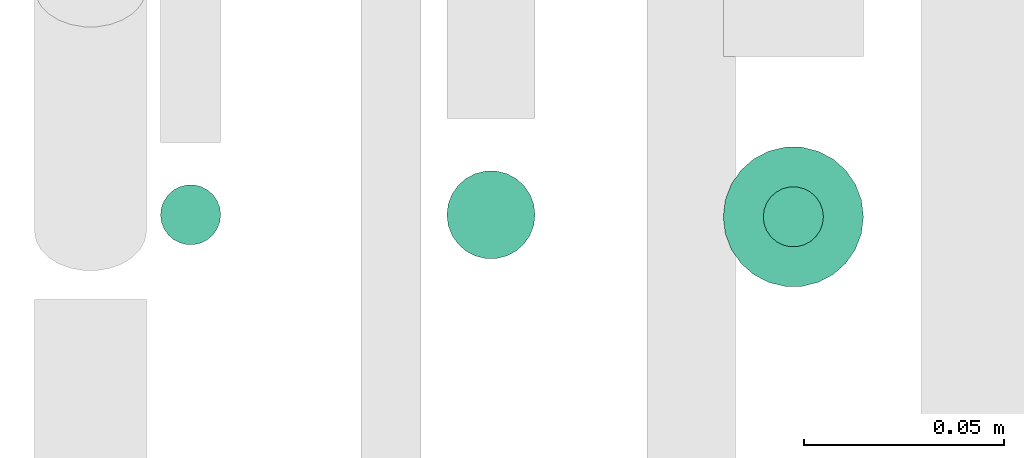
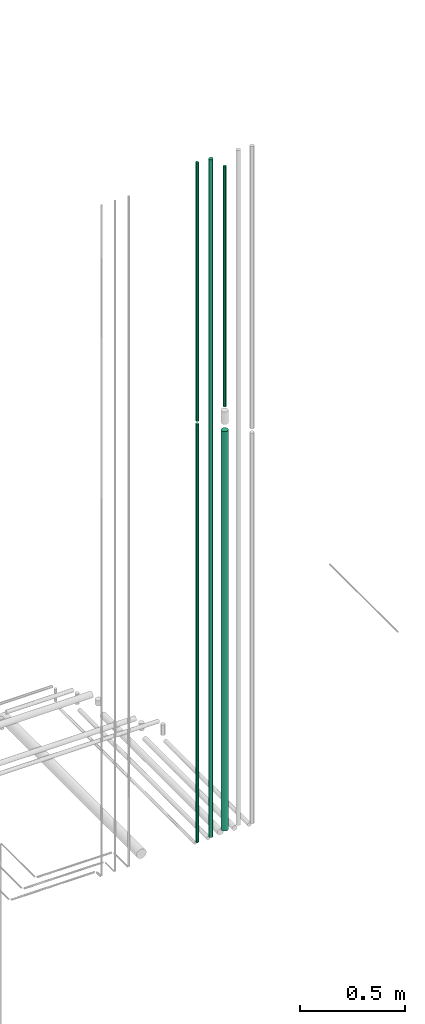
# One storey, part 91 of 331: 5 flow segments.
"""IFC2X3 building model written with IfcOpenShell, lengths in millimetres."""

from ifc_helpers import new_model, entity, si_unit, converted_unit, derived_unit, direction, frame, frame_2d, origin, origin_2d_with_axis, place, context, subcontext, project, spatial, circle, extrude, type_object, element, save


model = new_model("IFC2X3")

# Units and contexts
model_context = context("Model", 3, precision=0.01, world=origin(), true_north=direction((6.12303176911189e-17, 1.0)))
body_context = subcontext(model_context, "Body", "Model", "MODEL_VIEW")
ifc_project = project(units=[si_unit("LENGTHUNIT", "METRE", prefix="MILLI"), si_unit("AREAUNIT", "SQUARE_METRE"), si_unit("VOLUMEUNIT", "CUBIC_METRE"), converted_unit("PLANEANGLEUNIT", "DEGREE", entity("IfcRatioMeasure", 0.0174532925199433), si_unit("PLANEANGLEUNIT", "RADIAN"), dimensions=[0, 0, 0, 0, 0, 0, 0]), si_unit("MASSUNIT", "GRAM", prefix="KILO"), derived_unit("MASSDENSITYUNIT", [(si_unit("MASSUNIT", "GRAM", prefix="KILO"), 1), (si_unit("LENGTHUNIT", "METRE"), -3)]), derived_unit("MOMENTOFINERTIAUNIT", [(si_unit("LENGTHUNIT", "METRE"), 4)]), si_unit("TIMEUNIT", "SECOND"), si_unit("FREQUENCYUNIT", "HERTZ"), si_unit("THERMODYNAMICTEMPERATUREUNIT", "DEGREE_CELSIUS"), derived_unit("THERMALTRANSMITTANCEUNIT", [(si_unit("MASSUNIT", "GRAM", prefix="KILO"), 1), (si_unit("THERMODYNAMICTEMPERATUREUNIT", "KELVIN"), -1), (si_unit("TIMEUNIT", "SECOND"), -3)]), derived_unit("VOLUMETRICFLOWRATEUNIT", [(si_unit("LENGTHUNIT", "METRE"), 3), (si_unit("TIMEUNIT", "SECOND"), -1)]), derived_unit("MASSFLOWRATEUNIT", [(si_unit("MASSUNIT", "GRAM", prefix="KILO"), 1), (si_unit("TIMEUNIT", "SECOND"), -1)]), derived_unit("ROTATIONALFREQUENCYUNIT", [(si_unit("TIMEUNIT", "SECOND"), -1)]), si_unit("ELECTRICCURRENTUNIT", "AMPERE"), si_unit("ELECTRICVOLTAGEUNIT", "VOLT"), si_unit("POWERUNIT", "WATT"), si_unit("FORCEUNIT", "NEWTON", prefix="KILO"), si_unit("ILLUMINANCEUNIT", "LUX"), si_unit("LUMINOUSFLUXUNIT", "LUMEN"), si_unit("LUMINOUSINTENSITYUNIT", "CANDELA"), derived_unit("USERDEFINED", [(si_unit("MASSUNIT", "GRAM", prefix="KILO"), -1), (si_unit("LENGTHUNIT", "METRE"), -2), (si_unit("TIMEUNIT", "SECOND"), 3), (si_unit("LUMINOUSFLUXUNIT", "LUMEN"), 1)]), derived_unit("LINEARVELOCITYUNIT", [(si_unit("LENGTHUNIT", "METRE"), 1), (si_unit("TIMEUNIT", "SECOND"), -1)]), si_unit("PRESSUREUNIT", "PASCAL"), derived_unit("USERDEFINED", [(si_unit("LENGTHUNIT", "METRE"), -2), (si_unit("MASSUNIT", "GRAM", prefix="KILO"), 1), (si_unit("TIMEUNIT", "SECOND"), -2)]), derived_unit("LINEARFORCEUNIT", [(si_unit("MASSUNIT", "GRAM", prefix="KILO"), 1), (si_unit("LENGTHUNIT", "METRE"), 1), (si_unit("TIMEUNIT", "SECOND"), -2), (si_unit("LENGTHUNIT", "METRE"), -1)]), derived_unit("PLANARFORCEUNIT", [(si_unit("MASSUNIT", "GRAM", prefix="KILO"), 1), (si_unit("LENGTHUNIT", "METRE"), 1), (si_unit("TIMEUNIT", "SECOND"), -2), (si_unit("LENGTHUNIT", "METRE"), -2)])], contexts=[model_context])

# Site, building, storey
site_placement = place(None, frame((0.0, -0.00077364408347762, 0.0)))
site = spatial("IfcSite", under=ifc_project, at=site_placement, CompositionType="ELEMENT")
building_placement = place(site_placement, origin())
building = spatial("IfcBuilding", under=site, at=building_placement, CompositionType="ELEMENT")
storey_placement = place(building_placement, origin())
storey = spatial("IfcBuildingStorey", under=building, at=storey_placement, CompositionType="ELEMENT", Elevation=0.0)

# Flow segments
pipe_segment_type = type_object("IfcPipeSegmentType", PredefinedType="NOTDEFINED")
flow_segment_1_placement = place(building_placement, frame((65341.0166110417, 7656.05397754016, 20908.0)))
element("IfcFlowSegment", 1, at=flow_segment_1_placement, inside=storey, type_object=pipe_segment_type, context=body_context, shape_type="SweptSolid", body=[
    extrude(circle(Radius=7.5, at=origin_2d_with_axis()), frame((9.09527223591419, 9.09527223591636, 0.0), z_axis=(0.0, 0.0, 1.0), x_axis=(-1.0, 0.0, 0.0)), (0.0, 0.0, 1.0), 1499.00000000001),
])
flow_segment_2_placement = place(building_placement, frame((65412.5166110417, 7652.55397754015, 18474.0)))
element("IfcFlowSegment", 2, at=flow_segment_2_placement, inside=storey, type_object=pipe_segment_type, context=body_context, shape_type="SweptSolid", body=[
    extrude(circle(Radius=11.0, at=origin_2d_with_axis()), frame((12.5952722359134, 12.5952722359156, 0.0), z_axis=(0.0, 0.0, 1.0), x_axis=(-1.0, 0.0, 0.0)), (0.0, 0.0, 1.0), 3927.00000000002),
])
flow_segment_3_placement = place(building_placement, frame((65491.517459311, 7655.55312927097, 20939.0)))
element("IfcFlowSegment", 3, at=flow_segment_3_placement, inside=storey, type_object=pipe_segment_type, context=body_context, shape_type="SweptSolid", body=[
    extrude(circle(Radius=7.5, at=origin_2d_with_axis()), frame((9.09527223591419, 9.09527223591636, 0.0), z_axis=(0.0, 0.0, 1.0), x_axis=(-1.0, 0.0, 0.0)), (0.0, 0.0, 1.0), 1393.00000000003),
])
flow_segment_4_placement = place(building_placement, frame((65481.517459311, 7645.55312927097, 18490.0)))
element("IfcFlowSegment", 4, at=flow_segment_4_placement, inside=storey, type_object=pipe_segment_type, context=body_context, shape_type="SweptSolid", body=[
    extrude(circle(Radius=17.5, at=frame_2d((-8.66293703438714e-12, 0.0), x_axis=(1.0, 0.0))), frame((19.0952722359206, 19.0952722359163, 0.0)), (0.0, 0.0, 1.0), 2314.00000000001),
])
flow_segment_5_placement = place(building_placement, frame((65341.0166110417, 7656.05397754015, 18468.0)))
element("IfcFlowSegment", 5, at=flow_segment_5_placement, inside=storey, type_object=pipe_segment_type, context=body_context, shape_type="SweptSolid", body=[
    extrude(circle(Radius=7.5, at=origin_2d_with_axis()), frame((9.09527223591419, 9.09527223591636, 0.0), z_axis=(0.0, 0.0, 1.0), x_axis=(-1.0, 0.0, 0.0)), (0.0, 0.0, 1.0), 2424.00000000002),
])

save(model, "model.ifc")
